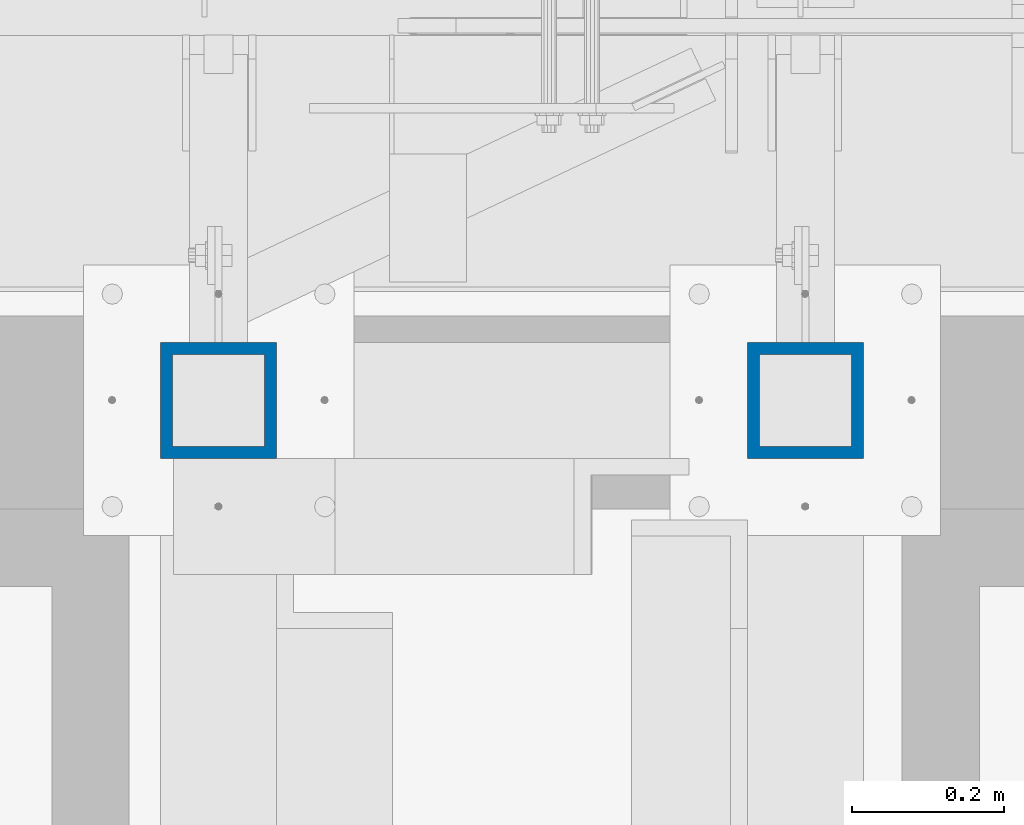
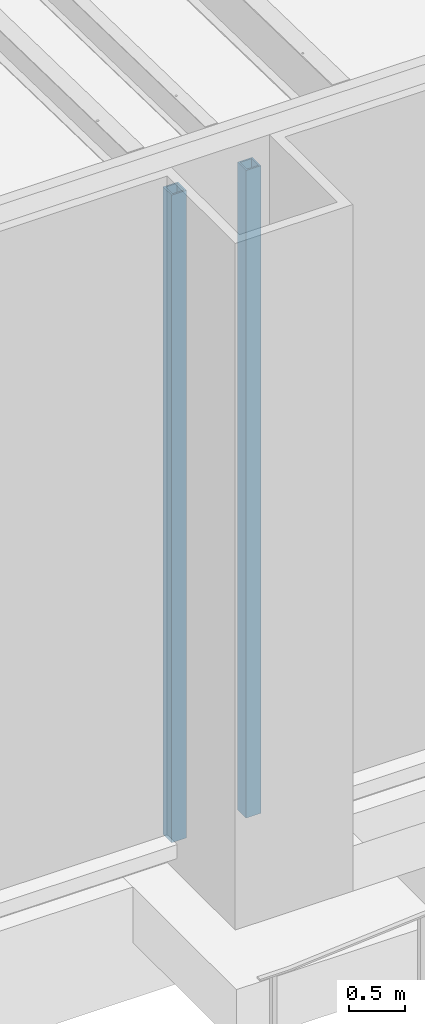
# One storey, part 877 of 1763: 2 columns, 1 element without a shape of its own.
"""IFC2X3 building model written with IfcOpenShell, lengths in millimetres."""

from ifc_helpers import new_model, si_unit, frame, origin_with_axes, place, context, subcontext, project, spatial, faceted_brep, material, type_object, element, aggregate, save


model = new_model("IFC2X3")

# Units and contexts
model_context = context("Model", 3, precision=1e-05, world=origin_with_axes())
body_context = subcontext(model_context, "Body", "Model", "MODEL_VIEW")
ifc_project = project(units=[si_unit("LENGTHUNIT", "METRE", prefix="MILLI"), si_unit("AREAUNIT", "SQUARE_METRE"), si_unit("VOLUMEUNIT", "CUBIC_METRE"), si_unit("MASSUNIT", "GRAM", prefix="KILO"), si_unit("TIMEUNIT", "SECOND"), si_unit("PLANEANGLEUNIT", "RADIAN"), si_unit("SOLIDANGLEUNIT", "STERADIAN"), si_unit("THERMODYNAMICTEMPERATUREUNIT", "DEGREE_CELSIUS"), si_unit("LUMINOUSINTENSITYUNIT", "LUMEN")], contexts=[model_context])

# Site, building, storey
site_placement = place(None, origin_with_axes())
site = spatial("IfcSite", under=ifc_project, at=site_placement, CompositionType="ELEMENT")
building_placement = place(site_placement, origin_with_axes())
building = spatial("IfcBuilding", under=site, at=building_placement, Name="Undefined", CompositionType="ELEMENT")
storey_placement = place(building_placement, origin_with_axes())
storey = spatial("IfcBuildingStorey", under=building, at=storey_placement, Name="Undefined", CompositionType="ELEMENT", Elevation=0.0)

# Assembly, columns
assembly_placement = place(storey_placement, origin_with_axes())
assembly = element("IfcElementAssembly", 1, at=assembly_placement, inside=storey, Name="FRAME", AssemblyPlace="NOTDEFINED", PredefinedType="RIGID_FRAME")
ifc_material = material()
column_type = type_object("IfcColumnType", Name="HSS6X6X5/8", PredefinedType="NOTDEFINED")
column_1_placement = place(assembly_placement, frame((-80212.6370783858, -14208.1242675181, 5029.2), z_axis=(0.0, 1.0, 0.0), x_axis=(0.0, 0.0, 1.0)))
column_1 = element("IfcColumn", 2, at=column_1_placement, type_object=column_type, material=ifc_material, Name="COLUMN", ObjectType="HSS6X6X5/8", context=body_context, shape_type="Brep", body=[
    faceted_brep([(63.4999999999973, 60.3249999999971, -60.3250000000007), (63.4999999999973, -60.3249999999971, -60.3250000000007), (7156.45, -60.3249999999971, -60.3250000000007), (7156.45, 60.3249999999971, -60.3250000000007), (63.4999999999973, -60.3249999999971, 60.3250000000007), (7156.45, -60.3249999999971, 60.3250000000007), (63.4999999999973, 60.3249999999971, 60.3250000000007), (7156.45, 60.3249999999971, 60.3250000000007), (63.4999999999973, 76.1999999999971, -76.2000000000007), (63.4999999999973, 76.1999999999971, 76.2000000000007), (7156.45, 76.1999999999971, 76.2000000000007), (7156.45, 76.1999999999971, -76.2000000000007), (63.4999999999973, -76.1999999999971, 76.2000000000007), (7156.45, -76.1999999999971, 76.2000000000007), (63.4999999999973, -76.1999999999971, -76.2000000000007), (7156.45, -76.1999999999971, -76.2000000000007)], [[[0, 1, 2, 3]], [[1, 4, 5, 2]], [[4, 6, 7, 5]], [[6, 0, 3, 7]], [[8, 9, 10, 11]], [[9, 12, 13, 10]], [[12, 14, 15, 13]], [[14, 8, 11, 15]], [[13, 15, 11, 10], [5, 7, 3, 2]], [[14, 12, 9, 8], [6, 4, 1, 0]]]),
])
column_2_placement = place(assembly_placement, frame((-80984.1622736984, -14208.1242675181, 5029.2), z_axis=(0.0, 1.0, 0.0), x_axis=(0.0, 0.0, 1.0)))
column_2 = element("IfcColumn", 3, at=column_2_placement, type_object=column_type, material=ifc_material, Name="COLUMN", ObjectType="HSS6X6X5/8", context=body_context, shape_type="Brep", body=[
    faceted_brep([(63.4999999999973, 60.3249999999971, -60.3250000000007), (63.4999999999973, -60.3249999999971, -60.3250000000007), (7156.45, -60.3249999999971, -60.3250000000007), (7156.45, 60.3249999999971, -60.3250000000007), (63.4999999999973, -60.3249999999971, 60.3250000000007), (7156.45, -60.3249999999971, 60.3250000000007), (63.4999999999973, 60.3249999999971, 60.3250000000007), (7156.45, 60.3249999999971, 60.3250000000007), (63.4999999999973, 76.1999999999971, -76.2000000000007), (63.4999999999973, 76.1999999999971, 76.2000000000007), (7156.45, 76.1999999999971, 76.2000000000007), (7156.45, 76.1999999999971, -76.2000000000007), (63.4999999999973, -76.1999999999971, 76.2000000000007), (7156.45, -76.1999999999971, 76.2000000000007), (63.4999999999973, -76.1999999999971, -76.2000000000007), (7156.45, -76.1999999999971, -76.2000000000007)], [[[0, 1, 2, 3]], [[1, 4, 5, 2]], [[4, 6, 7, 5]], [[6, 0, 3, 7]], [[8, 9, 10, 11]], [[9, 12, 13, 10]], [[12, 14, 15, 13]], [[14, 8, 11, 15]], [[13, 15, 11, 10], [5, 7, 3, 2]], [[14, 12, 9, 8], [6, 4, 1, 0]]]),
])
aggregate(assembly, [column_1, column_2])

save(model, "model.ifc")
